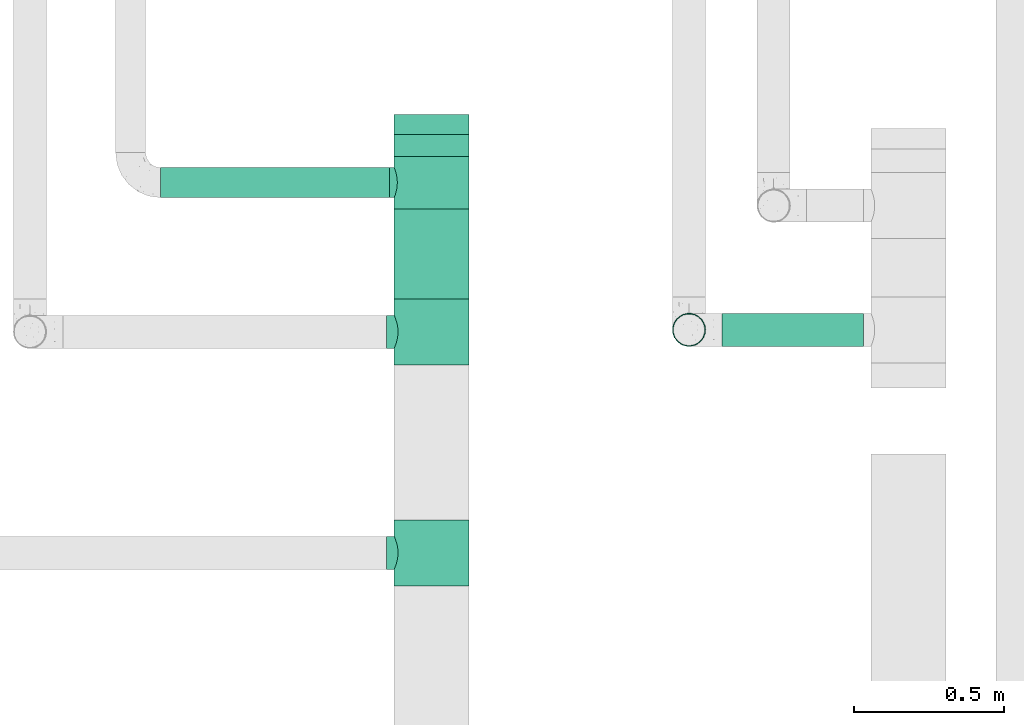
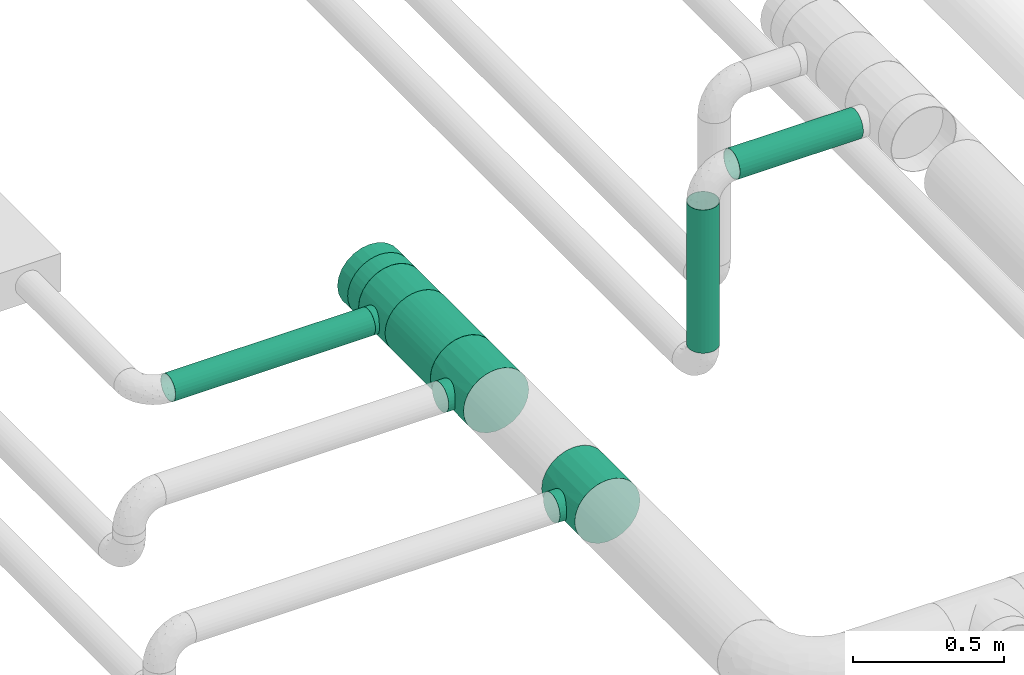
# One storey, part 39 of 91: 5 flow segments, 4 flow fittings.
"""IFC2X3 building model written with IfcOpenShell, lengths in millimetres."""

import ifcopenshell
import ifcopenshell.guid

model = None  # the IFC model being written
_history = None  # IfcOwnerHistory: only IFC2X3 demands one
_inside = {}  # id of a spatial element -> (the spatial element, [elements in it])
_under = {}  # id of a project, library or spatial element -> (it, [spatial elements below it])
_declared = {}  # id of a project -> (the project, [libraries it declares])
_typed = {}  # id of a type object -> (the type object, [elements of that type])
_made_of = {}  # id of a material, layer set ... -> (it, [elements and type objects made of it])


def new_model(schema):
    """Start an empty IFC model of exactly this schema.

    Asked for "IFC4X3", IfcOpenShell would pick the latest addendum, in which some entities
    have other attributes; the version numbers below select the first issue.
    IFC2X3 requires an IfcOwnerHistory on every rooted entity: one is made here for all.
    """
    global model, _history
    if schema == "IFC4X3":
        model = ifcopenshell.file(schema_version=(4, 3, 0, 0))
    else:
        model = ifcopenshell.file(schema=schema)
    _inside.clear()
    _under.clear()
    _declared.clear()
    _typed.clear()
    _made_of.clear()
    _history = None
    if model.schema == "IFC2X3":
        org = make("IfcOrganization", Name="unknown")
        user = make(
            "IfcPersonAndOrganization",
            ThePerson=make("IfcPerson", FamilyName="unknown"),
            TheOrganization=org,
        )
        app = make(
            "IfcApplication",
            ApplicationDeveloper=org,
            Version="unknown",
            ApplicationFullName="unknown",
            ApplicationIdentifier="unknown",
        )
        _history = make(
            "IfcOwnerHistory",
            OwningUser=user,
            OwningApplication=app,
            ChangeAction="ADDED",
            CreationDate=0,
        )
    return model


def make(cls, **values):
    """One entity of the class cls with the attributes given. An attribute that is None is left unset."""
    return model.create_entity(
        cls, **{name: value for name, value in values.items() if value is not None}
    )


def entity(cls, *values):
    """Any entity or typed value of the class cls, its attributes in the order of the schema. None: left unset."""
    e = model.create_entity(cls)
    for i, value in enumerate(values):
        if value is not None:
            e[i] = value
    return e


def rooted(cls, **values):
    """An entity with a GlobalId (a new one), such as an element, a storey or a relation."""
    return make(cls, GlobalId=ifcopenshell.guid.new(), OwnerHistory=_history, **values)


def si_unit(unit_type, name, prefix=None):
    """IfcSIUnit, for example si_unit("LENGTHUNIT", "METRE", prefix="MILLI")."""
    return make("IfcSIUnit", UnitType=unit_type, Prefix=prefix, Name=name)


def converted_unit(unit_type, name, factor, base, dimensions=None, offset=None):
    """IfcConversionBasedUnit, such as the inch: factor (a typed value) times the base unit."""
    return make(
        "IfcConversionBasedUnit"
        if offset is None
        else "IfcConversionBasedUnitWithOffset",
        ConversionOffset=offset,
        Dimensions=None
        if dimensions is None
        else entity("IfcDimensionalExponents", *dimensions),
        UnitType=unit_type,
        Name=name,
        ConversionFactor=make(
            "IfcMeasureWithUnit", ValueComponent=factor, UnitComponent=base
        ),
    )


def derived_unit(unit_type, elements):
    """IfcDerivedUnit: a product of units, each with its exponent."""
    return make(
        "IfcDerivedUnit",
        Elements=[
            make("IfcDerivedUnitElement", Unit=unit, Exponent=power)
            for unit, power in elements
        ],
        UnitType=unit_type,
    )


def assignment(units):
    """IfcUnitAssignment: the units of a project."""
    return None if units is None else make("IfcUnitAssignment", Units=units)


def point(xyz):
    """IfcCartesianPoint."""
    return None if xyz is None else make("IfcCartesianPoint", Coordinates=xyz)


def direction(xyz):
    """IfcDirection."""
    return None if xyz is None else make("IfcDirection", DirectionRatios=xyz)


def frame(location, z_axis=None, x_axis=None):
    """IfcAxis2Placement3D, a coordinate frame: its origin and axes. An axis left out is left unset."""
    return make(
        "IfcAxis2Placement3D",
        Location=point(location),
        Axis=direction(z_axis),
        RefDirection=direction(x_axis),
    )


def frame_2d(location, x_axis=None):
    """IfcAxis2Placement2D, a coordinate frame in the plane: its origin and x axis."""
    return make(
        "IfcAxis2Placement2D", Location=point(location), RefDirection=direction(x_axis)
    )


def origin_with_axes():
    """The frame at (0, 0, 0) with the z axis (0, 0, 1) and the x axis (1, 0, 0) written out."""
    return frame((0.0, 0.0, 0.0), z_axis=(0.0, 0.0, 1.0), x_axis=(1.0, 0.0, 0.0))


def origin_2d_with_axis():
    """The frame at (0, 0) in the plane with the x axis (1, 0) written out."""
    return frame_2d((0.0, 0.0), x_axis=(1.0, 0.0))


def place(relative_to, where):
    """IfcLocalPlacement: puts the frame where relative to a parent placement (None: the world)."""
    return make(
        "IfcLocalPlacement", PlacementRelTo=relative_to, RelativePlacement=where
    )


def context(
    kind, dimensions, precision=None, world=None, true_north=None, identifier=None
):
    """IfcGeometricRepresentationContext, for example the 3D "Model" context."""
    return make(
        "IfcGeometricRepresentationContext",
        ContextIdentifier=identifier,
        ContextType=kind,
        CoordinateSpaceDimension=dimensions,
        Precision=precision,
        WorldCoordinateSystem=world,
        TrueNorth=true_north,
    )


def subcontext(parent, identifier, kind, view, scale=None):
    """IfcGeometricRepresentationSubContext, for example "Body" below "Model"."""
    return make(
        "IfcGeometricRepresentationSubContext",
        ContextIdentifier=identifier,
        ContextType=kind,
        ParentContext=parent,
        TargetScale=scale,
        TargetView=view,
    )


def project(units=None, contexts=None):
    """IfcProject with its units and contexts."""
    return rooted(
        "IfcProject",
        Name="project",
        RepresentationContexts=contexts,
        UnitsInContext=assignment(units),
    )


def spatial(cls, under=None, at=None, **own):
    """A site, building, storey or space (cls), placed at a placement, below another one or the project."""
    s = rooted(cls, ObjectPlacement=at, **own)
    if under is not None:
        _under.setdefault(under.id(), (under, []))[1].append(s)
    return s


def profile(cls, at=None, kind="AREA", **sizes):
    """A parametric profile (cls). Its sizes go by their IFC names, for example OverallWidth=200.0."""
    return make(cls, ProfileType=kind, Position=at, **sizes)


def hollow_circle(**sizes):
    """IfcCircleHollowProfileDef."""
    return profile("IfcCircleHollowProfileDef", **sizes)


def extrude(swept, where, along, depth):
    """IfcExtrudedAreaSolid: the profile swept, set in the frame where, extruded along a direction by depth."""
    return make(
        "IfcExtrudedAreaSolid",
        SweptArea=swept,
        Position=where,
        ExtrudedDirection=direction(along),
        Depth=depth,
    )


def faces_of(points, faces, orient=None, outer=None):
    """IfcFace entities. A face is a list of loops; a loop is a list of indices into points, from 0.

    orient and outer hold one flag for each loop. By default every Orientation is true, the
    first loop of a face is its IfcFaceOuterBound and the others are IfcFaceBound.
    """
    made = []
    for i, loops in enumerate(faces):
        bounds = []
        for j, loop in enumerate(loops):
            is_outer = j == 0 if outer is None else outer[i][j]
            bounds.append(
                make(
                    "IfcFaceOuterBound" if is_outer else "IfcFaceBound",
                    Bound=make("IfcPolyLoop", Polygon=[points[k] for k in loop]),
                    Orientation=True if orient is None else orient[i][j],
                )
            )
        made.append(make("IfcFace", Bounds=bounds))
    return made


def open_shell(faces, orient=None, outer=None):
    """The faces of one IfcOpenShell. surface_model builds it on its shared points."""
    return ("IfcOpenShell", faces, orient, outer)


def surface_model(cls, points, shells):
    """IfcFaceBasedSurfaceModel or IfcShellBasedSurfaceModel (cls): surfaces that need not close."""
    shared = [point(p) for p in points]
    made = [make(c, CfsFaces=faces_of(shared, fs, o, b)) for c, fs, o, b in shells]
    if cls == "IfcFaceBasedSurfaceModel":
        return make(cls, FbsmFaces=made)
    return make(cls, SbsmBoundary=made)


def shape(context_of_items, identifier, shape_type, items):
    """IfcShapeRepresentation: the items that make up one representation, for example the "Body"."""
    return make(
        "IfcShapeRepresentation",
        ContextOfItems=context_of_items,
        RepresentationIdentifier=identifier,
        RepresentationType=shape_type,
        Items=items,
    )


def source(mapping_origin, context_of_items, identifier, shape_type, items):
    """IfcRepresentationMap: a shape defined once, which mapped items show again and again."""
    return make(
        "IfcRepresentationMap",
        MappingOrigin=mapping_origin,
        MappedRepresentation=shape(context_of_items, identifier, shape_type, items),
    )


def transform(
    local_origin,
    x_axis=None,
    y_axis=None,
    z_axis=None,
    scale=None,
    scale2=None,
    scale3=None,
    uniform=True,
):
    """IfcCartesianTransformationOperator3D, or its non-uniform kind. x_axis, y_axis, z_axis: its Axis1, 2, 3."""
    if uniform:
        return make(
            "IfcCartesianTransformationOperator3D",
            Axis1=direction(x_axis),
            Axis2=direction(y_axis),
            LocalOrigin=point(local_origin),
            Scale=scale,
            Axis3=direction(z_axis),
        )
    return make(
        "IfcCartesianTransformationOperator3DnonUniform",
        Axis1=direction(x_axis),
        Axis2=direction(y_axis),
        LocalOrigin=point(local_origin),
        Scale=scale,
        Axis3=direction(z_axis),
        Scale2=scale2,
        Scale3=scale3,
    )


def mapped(mapping_source, mapping_target):
    """IfcMappedItem: shows the shape of a source again, moved by a transform."""
    return make(
        "IfcMappedItem", MappingSource=mapping_source, MappingTarget=mapping_target
    )


def material(Name=None, Category=None):
    """IfcMaterial."""
    return make("IfcMaterial", Name=Name, Category=Category)


def layer(
    of_material, thickness, ventilated=None, Name=None, Category=None, Priority=None
):
    """IfcMaterialLayer: one layer of a wall or slab, of a material (None: an air gap)."""
    return make(
        "IfcMaterialLayer",
        Material=of_material,
        LayerThickness=thickness,
        IsVentilated=ventilated,
        Name=Name,
        Category=Category,
        Priority=Priority,
    )


def layer_set(layers, Name=None):
    """IfcMaterialLayerSet."""
    return make("IfcMaterialLayerSet", MaterialLayers=layers, LayerSetName=Name)


def layer_usage(for_layer_set, set_direction, sense, offset, extent=None):
    """IfcMaterialLayerSetUsage: how a layer set lies in its element."""
    return make(
        "IfcMaterialLayerSetUsage",
        ForLayerSet=for_layer_set,
        LayerSetDirection=set_direction,
        DirectionSense=sense,
        OffsetFromReferenceLine=offset,
        ReferenceExtent=extent,
    )


def made_of(thing, what):
    """Note that an element or type object is made of a material, layer set ...; save() writes the relation."""
    if what is not None:
        _made_of.setdefault(what.id(), (what, []))[1].append(thing)
    return thing


def type_object(cls, material=None, **own):
    """A type object (cls), such as IfcWallType, which elements share."""
    return made_of(rooted(cls, **own), material)


def element(
    cls,
    number,
    at=None,
    inside=None,
    cuts=None,
    type_object=None,
    material=None,
    context=None,
    identifier="Body",
    shape_type=None,
    held_by="IfcProductDefinitionShape",
    body=None,
    shapes=None,
    **own,
):
    """One element of the class cls, such as IfcWall. Its Tag is "e" and its number.

    at: its placement. inside: the storey or other place that contains it. cuts: it is an
    opening in that element (IfcRelVoidsElement). A single representation is given by context,
    identifier, shape_type and body (its items); several are given by shapes. held_by: the class
    of the entity that holds the representations. save() writes the other relations.
    """
    e = rooted(cls, Tag="e%d" % number, ObjectPlacement=at, **own)
    if body is not None:
        shapes = [shape(context, identifier, shape_type, body)]
    if shapes is not None:
        e.Representation = make(held_by, Representations=shapes)
    if inside is not None:
        _inside.setdefault(inside.id(), (inside, []))[1].append(e)
    if cuts is not None:
        rooted(
            "IfcRelVoidsElement", RelatingBuildingElement=cuts, RelatedOpeningElement=e
        )
    if type_object is not None:
        _typed.setdefault(type_object.id(), (type_object, []))[1].append(e)
    return made_of(e, material)


def aggregate(whole, parts):
    """IfcRelAggregates: a whole, such as a stair, and the parts it consists of."""
    return rooted("IfcRelAggregates", RelatingObject=whole, RelatedObjects=parts)


def save(model, path):
    """Write the relations noted so far, then the file.

    IfcRelAggregates (storeys below a building ...), IfcRelContainedInSpatialStructure (elements
    in a storey), IfcRelDefinesByType, IfcRelAssociatesMaterial and IfcRelDeclares: one each for
    every whole, place, type object, material and project.
    """
    for whole, parts in _under.values():
        aggregate(whole, parts)
    for where, things in _inside.values():
        rooted(
            "IfcRelContainedInSpatialStructure",
            RelatedElements=things,
            RelatingStructure=where,
        )
    for kind, things in _typed.values():
        rooted("IfcRelDefinesByType", RelatedObjects=things, RelatingType=kind)
    for what, things in _made_of.values():
        rooted("IfcRelAssociatesMaterial", RelatedObjects=things, RelatingMaterial=what)
    for by, libraries in _declared.values():
        rooted("IfcRelDeclares", RelatingContext=by, RelatedDefinitions=libraries)
    model.write(path)


model = new_model("IFC2X3")

# Units and contexts
model_context = context("Model", 3, precision=1e-05, world=origin_with_axes(), true_north=direction((0.0, 1.0)))
body_context = subcontext(model_context, "Body", "Model", "MODEL_VIEW")
ifc_project = project(units=[si_unit("AREAUNIT", "SQUARE_METRE"), si_unit("VOLUMEUNIT", "CUBIC_METRE", prefix="DECI"), si_unit("TIMEUNIT", "SECOND"), si_unit("THERMODYNAMICTEMPERATUREUNIT", "DEGREE_CELSIUS"), si_unit("PRESSUREUNIT", "PASCAL"), si_unit("MASSUNIT", "GRAM", prefix="KILO"), si_unit("LENGTHUNIT", "METRE", prefix="MILLI"), si_unit("POWERUNIT", "WATT"), si_unit("ELECTRICCURRENTUNIT", "AMPERE"), si_unit("ELECTRICVOLTAGEUNIT", "VOLT"), derived_unit("VOLUMETRICFLOWRATEUNIT", [(si_unit("VOLUMEUNIT", "CUBIC_METRE", prefix="DECI"), 1), (si_unit("TIMEUNIT", "SECOND"), -1)]), derived_unit("LINEARVELOCITYUNIT", [(si_unit("LENGTHUNIT", "METRE"), 1), (si_unit("TIMEUNIT", "SECOND"), -1)]), derived_unit("MASSDENSITYUNIT", [(si_unit("MASSUNIT", "GRAM", prefix="KILO"), 1), (si_unit("VOLUMEUNIT", "CUBIC_METRE"), -1)]), converted_unit("PLANEANGLEUNIT", "DEGREE", entity("IfcRatioMeasure", 0.01745), si_unit("PLANEANGLEUNIT", "RADIAN"), dimensions=[0, 0, 0, 0, 0, 0, 0])], contexts=[model_context])

# Site, building, storey
site_placement = place(None, origin_with_axes())
site = spatial("IfcSite", under=ifc_project, at=site_placement, CompositionType="ELEMENT")
building_placement = place(site_placement, origin_with_axes())
building = spatial("IfcBuilding", under=site, at=building_placement, Name="mc-building", CompositionType="ELEMENT")
storey_placement = place(building_placement, frame((0.0, 0.0, 8700.0), z_axis=(0.0, 0.0, 1.0), x_axis=(1.0, 0.0, 0.0)))
storey = spatial("IfcBuildingStorey", under=building, at=storey_placement, CompositionType="ELEMENT", Elevation=8700.0)

# Flow fittings
duct_fitting_type_1 = type_object("IfcDuctFittingType", PredefinedType="JUNCTION")
shared_shape_1 = source(origin_with_axes(), body_context, "Body", "SurfaceModel", [
    surface_model("IfcShellBasedSurfaceModel", [(0.0, -150.0, -55.0), (14.23505, -150.0, -53.12592), (-14.23505, -150.0, -53.12592), (-53.12592, -150.0, 14.23505), (-27.5, -150.0, -47.63139), (-47.63139, -150.0, -27.5), (-38.89087, -150.0, -38.89087), (55.0, -150.0, 0.0), (53.12592, -150.0, 14.23505), (38.89087, -150.0, -38.89087), (27.5, -150.0, -47.63139), (53.12592, -150.0, -14.23505), (47.63139, -150.0, -27.5), (-53.12592, -150.0, -14.23505), (-47.63139, -150.0, 27.5), (-38.89087, -150.0, 38.89087), (14.23505, -150.0, 53.12592), (-27.5, -150.0, 47.63139), (-14.23505, -150.0, 53.12592), (47.63139, -150.0, 27.5), (38.89087, -150.0, 38.89087), (27.5, -150.0, 47.63139), (0.0, -150.0, 55.0), (-55.0, -150.0, 0.0), (0.0, -112.24973, 55.0), (-12.37766, -112.9301, 53.58912), (-24.01261, -114.7894, 49.48125), (-34.33641, -117.38394, 42.96523), (-42.94114, -120.18295, 34.36653), (-49.47537, -122.66953, 24.02472), (-53.59142, -124.38666, 12.36769), (-55.0, -125.0, 0.0), (-49.46959, -122.66719, -24.03663), (-42.93393, -120.18037, -34.37554), (-53.588, -124.38519, -12.38248), (-34.32718, -117.38124, -42.9726), (-24.00081, -114.78693, -49.48698), (-12.36238, -112.92842, -53.59265), (0.0, -112.24973, -55.0), (12.37766, -112.9301, -53.58912), (24.01261, -114.7894, -49.48125), (34.33641, -117.38394, -42.96523), (42.94114, -120.18295, -34.36653), (49.47537, -122.66953, -24.02472), (53.59142, -124.38666, -12.36769), (55.0, -125.0, 0.0), (49.47537, -122.66953, 24.02472), (42.94114, -120.18295, 34.36653), (53.59142, -124.38666, 12.36769), (34.33641, -117.38394, 42.96523), (24.01261, -114.7894, 49.48125), (12.37766, -112.9301, 53.58912), (-110.0, 0.0, -125.0), (-110.0, -32.35238, -120.74073), (-110.0, 32.35238, -120.74073), (-110.0, 120.74073, 32.35238), (-110.0, 62.5, -108.25318), (-110.0, 88.38835, -88.38835), (-110.0, 108.25318, -62.5), (-110.0, -125.0, 0.0), (-110.0, -120.74073, 32.35238), (-110.0, -88.38835, -88.38835), (-110.0, -62.5, -108.25318), (-110.0, -120.74073, -32.35238), (-110.0, -108.25318, -62.5), (-110.0, 120.74073, -32.35238), (-110.0, 108.25318, 62.5), (-110.0, 62.5, 108.25318), (-110.0, 32.35238, 120.74073), (-110.0, 88.38835, 88.38835), (-110.0, 0.0, 125.0), (-110.0, -108.25318, 62.5), (-110.0, -88.38835, 88.38835), (-110.0, -32.35238, 120.74073), (-110.0, -62.5, 108.25318), (-110.0, 125.0, 0.0), (110.0, 32.35238, -120.74073), (110.0, 125.0, 0.0), (110.0, 0.0, -125.0), (110.0, 62.5, -108.25318), (110.0, 88.38835, -88.38835), (110.0, 108.25318, -62.5), (110.0, -88.38835, -88.38835), (110.0, -120.74073, 32.35238), (110.0, -62.5, -108.25318), (110.0, -32.35238, -120.74073), (110.0, -108.25318, -62.5), (110.0, -120.74073, -32.35238), (110.0, -125.0, 0.0), (110.0, 120.74073, -32.35238), (110.0, 108.25318, 62.5), (110.0, 120.74073, 32.35238), (110.0, 88.38835, 88.38835), (110.0, 62.5, 108.25318), (110.0, 32.35238, 120.74073), (110.0, -62.5, 108.25318), (110.0, -108.25318, 62.5), (110.0, -88.38835, 88.38835), (110.0, -32.35238, 120.74073), (110.0, 0.0, 125.0), (-110.0, -122.87036, -16.17619), (110.0, -114.49695, -47.42619), (-110.0, -114.49695, -47.42619), (110.0, -122.87036, -16.17619), (110.0, -122.87036, 16.17619), (110.0, -114.49695, 47.42619), (-110.0, -122.87036, 16.17619), (-110.0, -114.49695, 47.42619)], [open_shell([[[0, 1, 2]], [[2, 3, 4]], [[5, 6, 3]], [[6, 4, 3]], [[2, 7, 8]], [[9, 7, 10]], [[1, 10, 7]], [[11, 7, 12]], [[9, 12, 7]], [[7, 2, 1]], [[5, 3, 13]], [[2, 14, 3]], [[2, 15, 14]], [[2, 16, 17]], [[17, 15, 2]], [[16, 18, 17]], [[2, 8, 19]], [[2, 19, 20]], [[2, 20, 21]], [[16, 2, 21]], [[16, 22, 18]], [[23, 13, 3]], [[22, 24, 25]], [[18, 25, 26]], [[22, 25, 18]], [[17, 27, 15]], [[17, 18, 26]], [[27, 17, 26]], [[28, 29, 14]], [[30, 31, 23]], [[29, 30, 3]], [[15, 28, 14]], [[3, 14, 29]], [[23, 3, 30]], [[28, 15, 27]], [[32, 33, 5]], [[34, 32, 13]], [[31, 34, 23]], [[23, 34, 13]], [[32, 5, 13]], [[33, 6, 5]], [[4, 35, 36]], [[36, 37, 2]], [[38, 0, 37]], [[4, 6, 35]], [[2, 4, 36]], [[37, 0, 2]], [[35, 6, 33]], [[0, 38, 39]], [[1, 39, 40]], [[0, 39, 1]], [[10, 41, 9]], [[10, 1, 40]], [[41, 10, 40]], [[42, 43, 12]], [[44, 45, 7]], [[43, 44, 11]], [[9, 42, 12]], [[7, 11, 44]], [[43, 11, 12]], [[42, 9, 41]], [[46, 47, 19]], [[48, 46, 8]], [[45, 48, 7]], [[7, 48, 8]], [[46, 19, 8]], [[47, 20, 19]], [[21, 49, 50]], [[50, 51, 16]], [[24, 22, 51]], [[20, 49, 21]], [[16, 21, 50]], [[22, 16, 51]], [[49, 20, 47]], [[52, 53, 54]], [[54, 55, 56]], [[57, 55, 58]], [[56, 55, 57]], [[54, 59, 60]], [[61, 59, 62]], [[54, 53, 62]], [[63, 59, 64]], [[61, 64, 59]], [[62, 59, 54]], [[65, 58, 55]], [[66, 55, 54]], [[67, 66, 54]], [[67, 54, 68]], [[69, 66, 67]], [[70, 68, 54]], [[60, 71, 54]], [[71, 72, 54]], [[73, 70, 74]], [[72, 74, 70]], [[54, 72, 70]], [[75, 65, 55]], [[76, 77, 78]], [[79, 77, 76]], [[80, 81, 77]], [[80, 77, 79]], [[82, 78, 83]], [[78, 82, 84]], [[84, 85, 78]], [[86, 83, 87]], [[86, 82, 83]], [[88, 87, 83]], [[77, 81, 89]], [[90, 78, 91]], [[78, 90, 92]], [[93, 94, 78]], [[78, 92, 93]], [[95, 78, 94]], [[78, 96, 83]], [[78, 97, 96]], [[94, 98, 95]], [[78, 95, 97]], [[99, 98, 94]], [[78, 77, 91]], [[68, 99, 94]], [[67, 94, 93]], [[70, 99, 68]], [[68, 94, 67]], [[93, 69, 67]], [[93, 92, 69]], [[55, 90, 91]], [[75, 91, 77]], [[92, 66, 69]], [[92, 90, 66]], [[66, 90, 55]], [[91, 75, 55]], [[89, 81, 65]], [[77, 89, 65]], [[65, 75, 77]], [[58, 65, 81]], [[81, 57, 58]], [[81, 80, 57]], [[54, 79, 76]], [[52, 76, 78]], [[80, 56, 57]], [[80, 79, 56]], [[56, 79, 54]], [[76, 52, 54]], [[85, 53, 78]], [[84, 62, 85]], [[82, 86, 38]], [[34, 59, 100]], [[39, 38, 86]], [[40, 101, 41]], [[84, 82, 61]], [[82, 38, 61]], [[85, 62, 53]], [[53, 52, 78]], [[37, 36, 64]], [[33, 102, 35]], [[61, 38, 64]], [[35, 102, 36]], [[61, 62, 84]], [[38, 37, 64]], [[39, 86, 40]], [[101, 42, 41]], [[40, 86, 101]], [[42, 87, 43]], [[88, 45, 44]], [[87, 103, 43]], [[44, 103, 88]], [[43, 103, 44]], [[63, 102, 33]], [[63, 33, 32]], [[102, 64, 36]], [[100, 63, 32]], [[31, 59, 34]], [[100, 32, 34]], [[101, 87, 42]], [[45, 88, 48]], [[104, 83, 46]], [[46, 83, 47]], [[46, 48, 104]], [[47, 83, 105]], [[96, 50, 105]], [[31, 30, 59]], [[59, 30, 106]], [[27, 107, 28]], [[60, 106, 29]], [[60, 29, 28]], [[107, 60, 28]], [[50, 96, 51]], [[50, 49, 105]], [[24, 51, 96]], [[29, 106, 30]], [[95, 98, 73]], [[74, 97, 95]], [[24, 96, 97]], [[70, 98, 99]], [[25, 24, 71]], [[48, 88, 104]], [[71, 107, 26]], [[71, 26, 25]], [[24, 72, 71]], [[26, 107, 27]], [[24, 97, 72]], [[97, 74, 72]], [[73, 74, 95]], [[98, 70, 73]], [[47, 105, 49]]])]),
])
for number, where, z_axis, x_axis in (
    (1, (6828.023, 10175.43966, 668.0), (0.0, 0.0, 1.0), (0.0, -1.0, 0.0)),
    (2, (6828.023, 9437.92738, 668.0), (0.0, 0.0, 1.0), (0.0, -1.0, 0.0)),
):
    element("IfcFlowFitting", number, at=place(storey_placement, frame(where, z_axis=z_axis, x_axis=x_axis)), inside=storey, type_object=duct_fitting_type_1, context=body_context, shape_type="MappedRepresentation", body=[
        mapped(shared_shape_1, transform((0.0, 0.0, 0.0), scale=1.0)),
    ])
duct_fitting_type_2 = type_object("IfcDuctFittingType", Name="EPF", PredefinedType="OBSTRUCTION")
shared_shape_2 = source(origin_with_axes(), body_context, "Body", "SurfaceModel", [
    surface_model("IfcShellBasedSurfaceModel", [(0.0, 62.5, -108.25318), (0.0, 32.35238, -120.74073), (0.0, 0.0, -125.0), (0.0, 88.38835, -88.38835), (0.0, 120.74073, -32.35238), (0.0, 108.25318, -62.5), (0.0, -62.5, 108.25318), (0.0, -120.74073, -32.35238), (0.0, -88.38835, -88.38835), (0.0, -108.25318, -62.5), (0.0, -62.5, -108.25318), (0.0, -32.35238, -120.74073), (0.0, -125.0, 0.0), (0.0, -120.74073, 32.35238), (0.0, 125.0, 0.0), (0.0, 108.25318, 62.5), (0.0, 120.74073, 32.35238), (0.0, 88.38835, 88.38835), (0.0, 62.5, 108.25318), (0.0, 32.35238, 120.74073), (0.0, 0.0, 125.0), (0.0, -108.25318, 62.5), (0.0, -88.38835, 88.38835), (0.0, -32.35238, 120.74073), (68.0, 32.35238, -120.74073), (68.0, 62.5, 108.25318), (68.0, 0.0, -125.0), (68.0, 88.38835, -88.38835), (68.0, 62.5, -108.25318), (68.0, 108.25318, -62.5), (68.0, 120.74073, -32.35238), (68.0, -32.35238, -120.74073), (68.0, 32.35238, 120.74073), (68.0, -62.5, -108.25318), (68.0, -108.25318, -62.5), (68.0, -88.38835, -88.38835), (68.0, -125.0, 0.0), (68.0, -120.74073, -32.35238), (68.0, 120.74073, 32.35238), (68.0, 108.25318, 62.5), (68.0, 88.38835, 88.38835), (68.0, -32.35238, 120.74073), (68.0, -108.25318, 62.5), (68.0, -120.74073, 32.35238), (68.0, -88.38835, 88.38835), (68.0, -62.5, 108.25318), (68.0, 0.0, 125.0), (68.0, 125.0, 0.0)], [open_shell([[[0, 1, 2]], [[3, 0, 2]], [[2, 4, 5]], [[3, 2, 5]], [[6, 2, 7]], [[8, 9, 10]], [[2, 11, 10]], [[10, 9, 2]], [[2, 9, 7]], [[12, 13, 7]], [[4, 2, 14]], [[15, 16, 14]], [[17, 15, 14]], [[18, 2, 19]], [[18, 17, 2]], [[2, 20, 19]], [[7, 21, 22]], [[21, 7, 13]], [[23, 20, 6]], [[7, 22, 6]], [[6, 20, 2]], [[2, 17, 14]], [[24, 25, 26]], [[27, 24, 28]], [[29, 30, 24]], [[29, 24, 27]], [[31, 26, 32]], [[33, 34, 35]], [[36, 33, 31]], [[34, 36, 37]], [[36, 34, 33]], [[36, 31, 32]], [[30, 25, 24]], [[38, 39, 30]], [[40, 30, 39]], [[32, 26, 25]], [[30, 40, 25]], [[41, 36, 32]], [[42, 43, 36]], [[44, 42, 36]], [[45, 44, 36]], [[45, 36, 41]], [[32, 46, 41]], [[38, 30, 47]], [[20, 46, 32]], [[19, 32, 25]], [[20, 32, 19]], [[17, 25, 40]], [[18, 19, 25]], [[25, 17, 18]], [[16, 39, 38]], [[14, 38, 47]], [[17, 39, 15]], [[15, 39, 16]], [[38, 14, 16]], [[39, 17, 40]], [[14, 47, 30]], [[4, 30, 29]], [[14, 30, 4]], [[3, 29, 27]], [[5, 4, 29]], [[29, 3, 5]], [[1, 28, 24]], [[2, 24, 26]], [[3, 28, 0]], [[0, 28, 1]], [[24, 2, 1]], [[28, 3, 27]], [[2, 26, 31]], [[11, 31, 33]], [[2, 31, 11]], [[8, 33, 35]], [[10, 11, 33]], [[33, 8, 10]], [[7, 34, 37]], [[12, 37, 36]], [[8, 34, 9]], [[9, 34, 7]], [[37, 12, 7]], [[34, 8, 35]], [[12, 36, 43]], [[13, 43, 42]], [[12, 43, 13]], [[22, 42, 44]], [[21, 13, 42]], [[42, 22, 21]], [[23, 45, 41]], [[20, 41, 46]], [[22, 45, 6]], [[6, 45, 23]], [[41, 20, 23]], [[45, 22, 44]]])]),
])
flow_fitting_1_placement = place(storey_placement, frame((6828.023, 10833.41275, 668.0), z_axis=(0.0, 0.0, 1.0), x_axis=(0.0, 1.0, 0.0)))
element("IfcFlowFitting", 3, at=flow_fitting_1_placement, inside=storey, type_object=duct_fitting_type_2, context=body_context, shape_type="MappedRepresentation", body=[
    mapped(shared_shape_2, transform((0.0, 0.0, 0.0), scale=1.0)),
])

# Flow segments
ifc_material = material(Name="FZ1")
ifc_layer = layer(ifc_material, 0.0)
ifc_layer_set = layer_set([ifc_layer], Name="FZ1")
ifc_layer_usage = layer_usage(ifc_layer_set, "AXIS1", "POSITIVE", 0.0)
duct_segment_type_1 = type_object("IfcDuctSegmentType", PredefinedType="RIGIDSEGMENT")
shared_shape_3 = source(origin_with_axes(), body_context, "Body", "SweptSolid", [
    extrude(hollow_circle(Radius=55.0, WallThickness=2.0, at=origin_2d_with_axis()), frame((0.0, 0.0, 0.0), z_axis=(1.0, 0.0, 0.0), x_axis=(0.0, 1.0, 0.0)), (0.0, 0.0, 1.0), 579.3),
])
flow_segment_1_placement = place(storey_placement, frame((7686.9773, 10182.03578, 1104.30701), z_axis=(0.0, 1.0, 0.0), x_axis=(0.0, 0.0, -1.0)))
element("IfcFlowSegment", 4, at=flow_segment_1_placement, inside=storey, type_object=duct_segment_type_1, material=ifc_layer_usage, context=body_context, shape_type="MappedRepresentation", body=[
    mapped(shared_shape_3, transform((0.0, 0.0, 0.0), scale=1.0)),
])
shared_shape_4 = source(origin_with_axes(), body_context, "Body", "SweptSolid", [
    extrude(hollow_circle(Radius=55.0, WallThickness=2.0, at=origin_2d_with_axis()), frame((0.0, 0.0, 0.0), z_axis=(1.0, 0.0, 0.0), x_axis=(0.0, 1.0, 0.0)), (0.0, 0.0, 1.0), 472.0),
])
flow_segment_2_placement = place(storey_placement, frame((8269.02679, 10182.03578, 1214.30701), z_axis=(0.0, 0.0, 1.0), x_axis=(-1.0, 0.0, 0.0)))
element("IfcFlowSegment", 5, at=flow_segment_2_placement, inside=storey, type_object=duct_segment_type_1, material=ifc_layer_usage, context=body_context, shape_type="MappedRepresentation", body=[
    mapped(shared_shape_4, transform((0.0, 0.0, 0.0), scale=1.0)),
])
shared_shape_5 = source(origin_with_axes(), body_context, "Body", "SweptSolid", [
    extrude(hollow_circle(Radius=50.0, WallThickness=2.0, at=origin_2d_with_axis()), frame((0.0, 0.0, 0.0), z_axis=(1.0, 0.0, 0.0), x_axis=(0.0, 1.0, 0.0)), (0.0, 0.0, 1.0), 764.7),
])
flow_segment_3_placement = place(storey_placement, frame((6688.023, 10673.26046, 668.0), z_axis=(0.0, 0.0, 1.0), x_axis=(-1.0, 0.0, 0.0)))
element("IfcFlowSegment", 6, at=flow_segment_3_placement, inside=storey, type_object=duct_segment_type_1, material=ifc_layer_usage, context=body_context, shape_type="MappedRepresentation", body=[
    mapped(shared_shape_5, transform((0.0, 0.0, 0.0), scale=1.0)),
])
duct_segment_type_2 = type_object("IfcDuctSegmentType", Name="Safe", PredefinedType="RIGIDSEGMENT")
shared_shape_6 = source(origin_with_axes(), body_context, "Body", "SweptSolid", [
    extrude(hollow_circle(Radius=125.0, WallThickness=2.0, at=origin_2d_with_axis()), frame((0.0, 0.0, 0.0), z_axis=(1.0, 0.0, 0.0), x_axis=(0.0, 1.0, 0.0)), (0.0, 0.0, 1.0), 72.7),
])
flow_segment_4_placement = place(storey_placement, frame((6828.023, 10760.76046, 668.0), z_axis=(0.0, 0.0, 1.0), x_axis=(0.0, 1.0, 0.0)))
element("IfcFlowSegment", 7, at=flow_segment_4_placement, inside=storey, type_object=duct_segment_type_2, material=ifc_layer_usage, Name="Safe", context=body_context, shape_type="MappedRepresentation", body=[
    mapped(shared_shape_6, transform((0.0, 0.0, 0.0), scale=1.0)),
])

# Flow fitting
shared_shape_7 = source(origin_with_axes(), body_context, "Body", "SurfaceModel", [
    surface_model("IfcShellBasedSurfaceModel", [(0.0, -140.0, -50.0), (12.94095, -140.0, -48.29629), (-12.94095, -140.0, -48.29629), (-48.29629, -140.0, 12.94095), (-25.0, -140.0, -43.30127), (-35.35534, -140.0, -35.35534), (-43.30127, -140.0, -25.0), (50.0, -140.0, 0.0), (48.29629, -140.0, 12.94095), (35.35534, -140.0, -35.35534), (25.0, -140.0, -43.30127), (48.29629, -140.0, -12.94095), (43.30127, -140.0, -25.0), (-48.29629, -140.0, -12.94095), (-43.30127, -140.0, 25.0), (-35.35534, -140.0, 35.35534), (-25.0, -140.0, 43.30127), (12.94095, -140.0, 48.29629), (-12.94095, -140.0, 48.29629), (43.30127, -140.0, 25.0), (35.35534, -140.0, 35.35534), (25.0, -140.0, 43.30127), (0.0, -140.0, 50.0), (-50.0, -140.0, 0.0), (0.0, -114.56439, 50.0), (-11.23344, -115.11381, 48.72176), (-21.81227, -116.62236, 44.99139), (-31.21528, -118.74087, 39.05901), (-39.0526, -121.03762, 31.2233), (-44.99266, -123.08265, 21.80964), (-48.72466, -124.49535, 11.22084), (-50.0, -125.0, 0.0), (-44.98471, -123.07975, -21.82604), (-39.04056, -121.03374, -31.23835), (-48.72121, -124.494, -11.23581), (-31.2003, -118.73693, -39.07098), (-21.79611, -116.61934, -44.99922), (-11.21877, -115.11239, -48.72514), (0.0, -114.56439, -50.0), (11.23344, -115.11381, -48.72176), (21.81227, -116.62236, -44.99139), (31.21528, -118.74087, -39.05901), (39.0526, -121.03762, -31.2233), (44.99266, -123.08265, -21.80964), (48.72466, -124.49535, -11.22084), (50.0, -125.0, 0.0), (44.99266, -123.08265, 21.80964), (39.0526, -121.03762, 31.2233), (48.72466, -124.49535, 11.22084), (31.21528, -118.74087, 39.05901), (21.81227, -116.62236, 44.99139), (11.23344, -115.11381, 48.72176), (-87.5, 0.0, -125.0), (-87.5, -32.35238, -120.74073), (-87.5, 32.35238, -120.74073), (-87.5, 120.74073, 32.35238), (-87.5, 62.5, -108.25318), (-87.5, 88.38835, -88.38835), (-87.5, 108.25318, -62.5), (-87.5, -125.0, 0.0), (-87.5, -120.74073, 32.35238), (-87.5, -88.38835, -88.38835), (-87.5, -62.5, -108.25318), (-87.5, -120.74073, -32.35238), (-87.5, -108.25318, -62.5), (-87.5, 120.74073, -32.35238), (-87.5, 108.25318, 62.5), (-87.5, 62.5, 108.25318), (-87.5, 32.35238, 120.74073), (-87.5, 88.38835, 88.38835), (-87.5, 0.0, 125.0), (-87.5, -108.25318, 62.5), (-87.5, -88.38835, 88.38835), (-87.5, -32.35238, 120.74073), (-87.5, -62.5, 108.25318), (-87.5, 125.0, 0.0), (87.5, 32.35238, -120.74073), (87.5, 125.0, 0.0), (87.5, 0.0, -125.0), (87.5, 62.5, -108.25318), (87.5, 108.25318, -62.5), (87.5, 88.38835, -88.38835), (87.5, -88.38835, -88.38835), (87.5, -120.74073, 32.35238), (87.5, -62.5, -108.25318), (87.5, -32.35238, -120.74073), (87.5, -108.25318, -62.5), (87.5, -120.74073, -32.35238), (87.5, -125.0, 0.0), (87.5, 120.74073, -32.35238), (87.5, 120.74073, 32.35238), (87.5, 108.25318, 62.5), (87.5, 62.5, 108.25318), (87.5, 32.35238, 120.74073), (87.5, 88.38835, 88.38835), (87.5, -62.5, 108.25318), (87.5, -108.25318, 62.5), (87.5, -88.38835, 88.38835), (87.5, -32.35238, 120.74073), (87.5, 0.0, 125.0), (-87.5, -122.87036, -16.17619), (87.5, -122.87036, -16.17619), (87.5, -122.87036, 16.17619), (-87.5, -122.87036, 16.17619)], [open_shell([[[0, 1, 2]], [[2, 3, 4]], [[5, 3, 6]], [[4, 3, 5]], [[2, 7, 8]], [[9, 7, 10]], [[1, 10, 7]], [[11, 7, 12]], [[9, 12, 7]], [[7, 2, 1]], [[13, 6, 3]], [[14, 3, 2]], [[15, 14, 2]], [[16, 2, 17]], [[16, 15, 2]], [[16, 17, 18]], [[2, 8, 19]], [[2, 19, 20]], [[20, 21, 2]], [[17, 2, 21]], [[17, 22, 18]], [[23, 13, 3]], [[22, 24, 25]], [[18, 25, 26]], [[22, 25, 18]], [[16, 27, 15]], [[16, 18, 26]], [[27, 16, 26]], [[28, 29, 14]], [[30, 31, 23]], [[29, 30, 3]], [[15, 28, 14]], [[3, 14, 29]], [[23, 3, 30]], [[28, 15, 27]], [[32, 33, 6]], [[34, 32, 13]], [[31, 34, 23]], [[23, 34, 13]], [[32, 6, 13]], [[33, 5, 6]], [[4, 35, 36]], [[36, 37, 2]], [[38, 0, 37]], [[5, 35, 4]], [[0, 2, 37]], [[36, 2, 4]], [[35, 5, 33]], [[0, 38, 39]], [[1, 39, 40]], [[0, 39, 1]], [[10, 41, 9]], [[10, 1, 40]], [[41, 10, 40]], [[42, 43, 12]], [[44, 45, 7]], [[43, 44, 11]], [[9, 42, 12]], [[11, 12, 43]], [[7, 11, 44]], [[42, 9, 41]], [[46, 47, 19]], [[48, 46, 8]], [[45, 48, 7]], [[7, 48, 8]], [[46, 19, 8]], [[47, 20, 19]], [[21, 49, 50]], [[50, 51, 17]], [[24, 22, 51]], [[20, 49, 21]], [[17, 21, 50]], [[22, 17, 51]], [[49, 20, 47]], [[52, 53, 54]], [[54, 55, 56]], [[57, 55, 58]], [[56, 55, 57]], [[54, 59, 60]], [[61, 59, 62]], [[54, 53, 62]], [[63, 59, 64]], [[61, 64, 59]], [[62, 59, 54]], [[65, 58, 55]], [[66, 55, 54]], [[67, 66, 54]], [[67, 54, 68]], [[69, 66, 67]], [[70, 68, 54]], [[60, 71, 54]], [[71, 72, 54]], [[73, 70, 74]], [[72, 74, 70]], [[54, 72, 70]], [[75, 65, 55]], [[76, 77, 78]], [[79, 77, 76]], [[80, 77, 81]], [[79, 81, 77]], [[82, 78, 83]], [[78, 84, 85]], [[78, 82, 84]], [[86, 83, 87]], [[86, 82, 83]], [[83, 88, 87]], [[77, 80, 89]], [[90, 91, 78]], [[78, 91, 92]], [[93, 78, 92]], [[92, 91, 94]], [[78, 93, 95]], [[78, 96, 83]], [[97, 96, 78]], [[97, 78, 95]], [[93, 98, 95]], [[93, 99, 98]], [[77, 90, 78]], [[68, 99, 93]], [[67, 93, 92]], [[70, 99, 68]], [[68, 93, 67]], [[92, 69, 67]], [[92, 94, 69]], [[55, 91, 90]], [[75, 90, 77]], [[94, 66, 69]], [[94, 91, 66]], [[66, 91, 55]], [[90, 75, 55]], [[89, 80, 65]], [[77, 89, 75]], [[65, 75, 89]], [[58, 65, 80]], [[80, 57, 58]], [[80, 81, 57]], [[54, 79, 76]], [[52, 76, 78]], [[81, 56, 57]], [[81, 79, 56]], [[56, 79, 54]], [[76, 52, 54]], [[85, 53, 78]], [[84, 62, 85]], [[64, 82, 86]], [[34, 59, 100]], [[39, 38, 86]], [[86, 40, 39]], [[84, 82, 61]], [[64, 86, 38]], [[85, 62, 53]], [[53, 52, 78]], [[37, 36, 64]], [[43, 101, 44]], [[61, 82, 64]], [[36, 63, 64]], [[61, 62, 84]], [[38, 37, 64]], [[41, 87, 42]], [[87, 41, 40]], [[42, 87, 43]], [[88, 45, 44]], [[87, 101, 43]], [[44, 101, 88]], [[63, 33, 32]], [[33, 63, 35]], [[35, 63, 36]], [[100, 63, 32]], [[31, 59, 34]], [[100, 32, 34]], [[87, 40, 86]], [[45, 88, 48]], [[102, 83, 46]], [[46, 83, 47]], [[46, 48, 102]], [[49, 47, 83]], [[83, 50, 49]], [[31, 30, 59]], [[59, 30, 103]], [[28, 27, 60]], [[60, 103, 29]], [[60, 29, 28]], [[27, 26, 60]], [[50, 96, 51]], [[96, 50, 83]], [[24, 51, 96]], [[48, 88, 102]], [[95, 98, 73]], [[74, 97, 95]], [[72, 96, 97]], [[70, 98, 99]], [[25, 24, 71]], [[26, 71, 60]], [[71, 26, 25]], [[96, 71, 24]], [[29, 103, 30]], [[96, 72, 71]], [[97, 74, 72]], [[73, 74, 95]], [[98, 70, 73]]])]),
])
flow_fitting_2_placement = place(storey_placement, frame((6828.023, 10673.26046, 668.0), z_axis=(0.0, 0.0, 1.0), x_axis=(0.0, -1.0, 0.0)))
element("IfcFlowFitting", 8, at=flow_fitting_2_placement, inside=storey, type_object=duct_fitting_type_1, context=body_context, shape_type="MappedRepresentation", body=[
    mapped(shared_shape_7, transform((0.0, 0.0, 0.0), scale=1.0)),
])

# Flow segment
shared_shape_8 = source(origin_with_axes(), body_context, "Body", "SweptSolid", [
    extrude(hollow_circle(Radius=125.0, WallThickness=2.0, at=origin_2d_with_axis()), frame((0.0, 0.0, 0.0), z_axis=(1.0, 0.0, 0.0), x_axis=(0.0, 1.0, 0.0)), (0.0, 0.0, 1.0), 300.3),
])
flow_segment_5_placement = place(storey_placement, frame((6828.023, 10285.43966, 668.0), z_axis=(0.0, 0.0, 1.0), x_axis=(0.0, 1.0, 0.0)))
element("IfcFlowSegment", 9, at=flow_segment_5_placement, inside=storey, type_object=duct_segment_type_2, material=ifc_layer_usage, Name="Safe", context=body_context, shape_type="MappedRepresentation", body=[
    mapped(shared_shape_8, transform((0.0, 0.0, 0.0), scale=1.0)),
])

save(model, "model.ifc")
